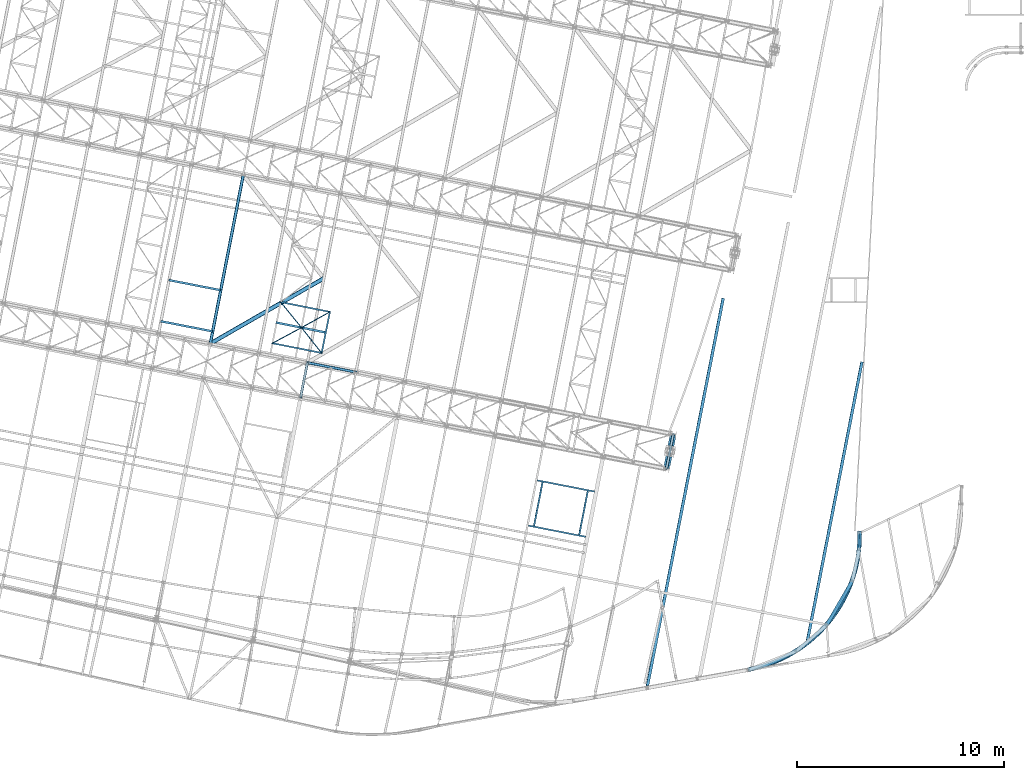
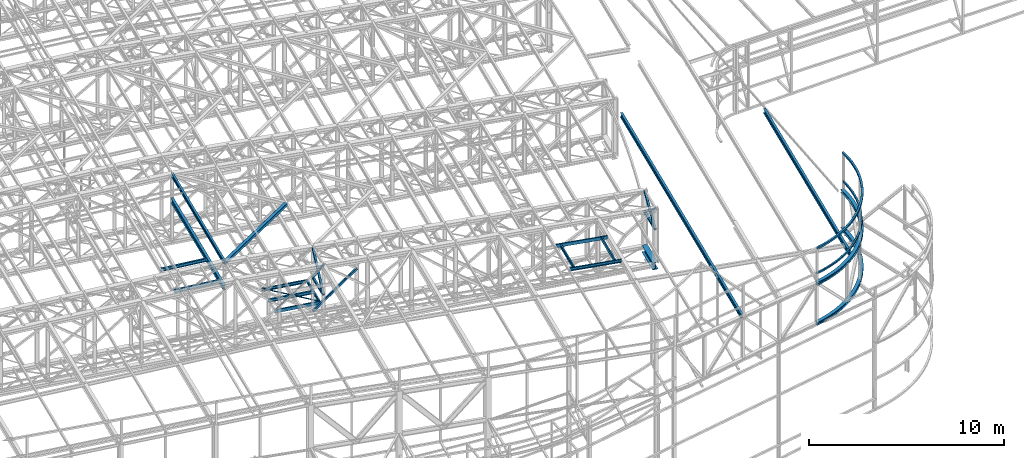
# One storey, part 59 of 215: 26 beams, 6 members, 32 elements without a shape of their own.
"""IFC2X3 building model written with IfcOpenShell, lengths in millimetres."""

from ifc_helpers import new_model, entity, si_unit, frame, origin_with_axes, origin_2d_with_axis, place, context, subcontext, project, spatial, hollow_rectangle, i_section, u_section, extrude, clip, halfspace, material, type_object, element, aggregate, save


model = new_model("IFC2X3")

# Units and contexts
model_context = context("Model", 3, precision=1e-05, world=origin_with_axes())
body_context = subcontext(model_context, "Body", "Model", "MODEL_VIEW")
ifc_project = project(units=[si_unit("LENGTHUNIT", "METRE", prefix="MILLI"), si_unit("AREAUNIT", "SQUARE_METRE"), si_unit("VOLUMEUNIT", "CUBIC_METRE"), si_unit("MASSUNIT", "GRAM", prefix="KILO"), si_unit("TIMEUNIT", "SECOND"), si_unit("PLANEANGLEUNIT", "RADIAN"), si_unit("SOLIDANGLEUNIT", "STERADIAN"), si_unit("THERMODYNAMICTEMPERATUREUNIT", "DEGREE_CELSIUS"), si_unit("LUMINOUSINTENSITYUNIT", "LUMEN")], contexts=[model_context])

# Site, building, storey
site_placement = place(None, origin_with_axes())
site = spatial("IfcSite", under=ifc_project, at=site_placement, CompositionType="ELEMENT")
building_placement = place(site_placement, origin_with_axes())
building = spatial("IfcBuilding", under=site, at=building_placement, Name="Undefined", CompositionType="ELEMENT")
storey_placement = place(building_placement, origin_with_axes())
storey = spatial("IfcBuildingStorey", under=building, at=storey_placement, Name="Undefined", CompositionType="ELEMENT", Elevation=0.0)

# Assembly, beam
assembly_1_placement = place(storey_placement, origin_with_axes())
assembly_1 = element("IfcElementAssembly", 1, at=assembly_1_placement, inside=storey, Name="Steel Assembly", AssemblyPlace="NOTDEFINED", PredefinedType="RIGID_FRAME")
ifc_material_1 = material(Name="STEEL/S275JR")
beam_type_1 = type_object("IfcBeamType", PredefinedType="NOTDEFINED")
beam_1_placement = place(assembly_1_placement, frame((98906.6966895589, 9997.56402703412, 12402.9925032266), z_axis=(0.0281714399984521, 0.00473133599973984, 0.999591908944881), x_axis=(-0.630520880023698, -0.775876050029161, 0.0214423610008059)))
beam_1 = element("IfcBeam", 2, at=beam_1_placement, type_object=beam_type_1, material=ifc_material_1, Name="LISSE", context=body_context, shape_type="SweptSolid", body=[
    entity("IfcRevolvedAreaSolid", entity("IfcRectangleHollowProfileDef", "AREA", None, entity("IfcAxis2Placement2D", entity("IfcCartesianPoint", [0.0, 0.0]), entity("IfcDirection", [1.0, 0.0])), 100.0, 100.0, 4.0, 4.0, 8.0), entity("IfcAxis2Placement3D", entity("IfcCartesianPoint", [8580.86874951581, -2.91266237782568e-11, 1.78921853461773e-12]), entity("IfcDirection", [-0.77200215890436, 0.635619907371541, 4.88367008734358e-18]), entity("IfcDirection", [-0.635619907371541, -0.77200215890436, -4.7317098688111e-19])), entity("IfcAxis1Placement", entity("IfcCartesianPoint", [6750.0, 0.0, 0.0]), entity("IfcDirection", [0.0, 1.0, 0.0])), 1.37762248286978),
])
aggregate(assembly_1, [beam_1])

assembly_2_placement = place(storey_placement, origin_with_axes())
assembly_2 = element("IfcElementAssembly", 3, at=assembly_2_placement, inside=storey, Name="Steel Assembly", AssemblyPlace="NOTDEFINED", PredefinedType="RIGID_FRAME")
beam_type_2 = type_object("IfcBeamType", Name="IPE240", PredefinedType="NOTDEFINED")
beam_2_placement = place(assembly_2_placement, frame((67523.0263426016, 19103.76567383, 12797.7153095357), z_axis=(0.0, 0.0, 1.0), x_axis=(0.191859470081235, 0.981422408415534, 0.0)))
beam_2 = element("IfcBeam", 4, at=beam_2_placement, type_object=beam_type_2, material=ifc_material_1, ObjectType="IPE240", context=body_context, shape_type="SweptSolid", body=[
    extrude(i_section(OverallWidth=120.0, OverallDepth=240.0, WebThickness=6.199999809, FlangeThickness=9.800000191, FilletRadius=15.0, at=origin_2d_with_axis()), frame((8299.99526300685, 1.47838788079098e-11, -1.71639879146031e-21), z_axis=(-1.0, 0.0, 0.0), x_axis=(-6.93889390390723e-18, -1.0, -3.46944695195361e-18)), (0.0, 0.0, 1.0), 8300.0),
])
aggregate(assembly_2, [beam_2])

assembly_3_placement = place(storey_placement, origin_with_axes())
assembly_3 = element("IfcElementAssembly", 5, at=assembly_3_placement, inside=storey, Name="Steel Assembly", AssemblyPlace="NOTDEFINED", PredefinedType="RIGID_FRAME")
beam_type_3 = type_object("IfcBeamType", Name="IPE270", PredefinedType="NOTDEFINED")
beam_3_placement = place(assembly_3_placement, frame((96342.8816697116, 4697.38975227182, 11822.2868772041), z_axis=(0.0304080349965938, -0.00594450399933318, 0.999519891888024), x_axis=(0.191859470081235, 0.981422408415534, 0.0)))
beam_3 = element("IfcBeam", 6, at=beam_3_placement, type_object=beam_type_3, material=ifc_material_1, ObjectType="IPE270", context=body_context, shape_type="SweptSolid", body=[
    extrude(i_section(OverallWidth=135.0, OverallDepth=270.0, WebThickness=6.599999905, FlangeThickness=10.19999981, FilletRadius=15.0, at=origin_2d_with_axis()), frame((13786.1928349318, 0.0, 1.81898940354586e-12), z_axis=(-1.0, 0.0, 0.0), x_axis=(-6.93889390390723e-18, -1.0, -3.46944695195361e-18)), (0.0, 0.0, 1.0), 13786.2),
])
aggregate(assembly_3, [beam_3])

assembly_4_placement = place(storey_placement, origin_with_axes())
assembly_4 = element("IfcElementAssembly", 7, at=assembly_4_placement, inside=storey, Name="Steel Assembly", AssemblyPlace="NOTDEFINED", PredefinedType="RIGID_FRAME")
beam_4_placement = place(assembly_4_placement, frame((88675.9862604393, 2825.15409559014, 12044.3992258659), z_axis=(0.0304080349965938, -0.00594450399933318, 0.999519891888024), x_axis=(0.191859470081235, 0.981422408415534, 0.0)))
beam_4 = element("IfcBeam", 8, at=beam_4_placement, type_object=beam_type_3, material=ifc_material_1, ObjectType="IPE270", context=body_context, shape_type="Clipping", body=[
    clip(extrude(i_section(OverallWidth=135.0, OverallDepth=270.0, WebThickness=6.599999905, FlangeThickness=10.19999981, FilletRadius=15.0, at=origin_2d_with_axis()), frame((18826.2441793608, 5.22533243878542e-13, -1.83531856741706e-12), z_axis=(-1.0, 0.0, 0.0), x_axis=(-6.93889390390723e-18, -1.0, -3.46944695195361e-18)), (0.0, 0.0, 1.0), 19120.8), halfspace(frame((-140.77964421397, -247.452609499334, 193.325370493829), z_axis=(0.932135442503494, 0.361935961367028, -0.0112194785146274), x_axis=(-1.11477173049934e-07, 0.0309836363285431, 0.999519891888024)), True)),
])
aggregate(assembly_4, [beam_4])

assembly_5_placement = place(storey_placement, origin_with_axes())
assembly_5 = element("IfcElementAssembly", 9, at=assembly_5_placement, inside=storey, Name="Steel Assembly", AssemblyPlace="NOTDEFINED", PredefinedType="RIGID_FRAME")
beam_type_4 = type_object("IfcBeamType", PredefinedType="NOTDEFINED")
beam_5_placement = place(assembly_5_placement, frame((98914.0804124177, 10055.2776774889, 14159.9992949207), z_axis=(0.0, 0.0, 1.0), x_axis=(-0.627240919701762, -0.778825287629687, -4.71999999842984e-07)))
beam_5 = element("IfcBeam", 10, at=beam_5_placement, type_object=beam_type_4, material=ifc_material_1, Name="LISSE", context=body_context, shape_type="SweptSolid", body=[
    entity("IfcRevolvedAreaSolid", entity("IfcRectangleHollowProfileDef", "AREA", None, entity("IfcAxis2Placement2D", entity("IfcCartesianPoint", [0.0, 0.0]), entity("IfcDirection", [1.0, 0.0])), 120.0, 120.0, 4.0, 4.0, 8.0), entity("IfcAxis2Placement3D", entity("IfcCartesianPoint", [8649.27113164034, 7.33174074846522e-14, 0.0]), entity("IfcDirection", [-0.75881988012704, 0.651300537021109, 4.46820122564736e-23]), entity("IfcDirection", [-0.651300537021109, -0.75881988012704, -5.20583006723259e-23])), entity("IfcAxis1Placement", entity("IfcCartesianPoint", [6640.0, 0.0, 0.0]), entity("IfcDirection", [0.0, 1.0, 0.0])), 1.4185941460835),
])
aggregate(assembly_5, [beam_5])

assembly_6_placement = place(storey_placement, origin_with_axes())
assembly_6 = element("IfcElementAssembly", 11, at=assembly_6_placement, inside=storey, Name="Steel Assembly", AssemblyPlace="NOTDEFINED", PredefinedType="RIGID_FRAME")
beam_type_5 = type_object("IfcBeamType", PredefinedType="NOTDEFINED")
beam_6_placement = place(assembly_6_placement, frame((89549.9522218589, 13065.5149440657, 10795.9999790824), z_axis=(0.981422364268518, -0.191859461052493, -0.000300197000082615), x_axis=(0.191859470081235, 0.981422408415534, 0.0)))
beam_6 = element("IfcBeam", 12, at=beam_6_placement, type_object=beam_type_5, material=ifc_material_1, context=body_context, shape_type="SweptSolid", body=[
    extrude(hollow_rectangle(XDim=120.0, YDim=120.0, WallThickness=5.0, InnerFilletRadius=5.0, OuterFilletRadius=10.0, at=origin_2d_with_axis()), frame((1699.99999941724, 1.81898940354586e-12, 0.0), z_axis=(-1.0, 0.0, 0.0), x_axis=(-6.93889390390723e-18, -1.0, -3.46944695195361e-18)), (0.0, 0.0, 1.0), 1700.0),
])
aggregate(assembly_6, [beam_6])

assembly_7_placement = place(storey_placement, origin_with_axes())
assembly_7 = element("IfcElementAssembly", 13, at=assembly_7_placement, inside=storey, Name="Steel Assembly", AssemblyPlace="NOTDEFINED", PredefinedType="RIGID_FRAME")
beam_7_placement = place(assembly_7_placement, frame((71884.9577831845, 16518.8662924301, 10796.0000008389), z_axis=(0.981422364268518, -0.191859461052493, -0.000300197000082615), x_axis=(0.191859470081235, 0.981422408415534, 0.0)))
beam_7 = element("IfcBeam", 14, at=beam_7_placement, type_object=beam_type_5, material=ifc_material_1, context=body_context, shape_type="SweptSolid", body=[
    extrude(hollow_rectangle(XDim=120.0, YDim=120.0, WallThickness=5.0, InnerFilletRadius=5.0, OuterFilletRadius=10.0, at=origin_2d_with_axis()), frame((1699.99999941724, 1.81898940354586e-12, 0.0), z_axis=(-1.0, 0.0, 0.0), x_axis=(-6.93889390390723e-18, -1.0, -3.46944695195361e-18)), (0.0, 0.0, 1.0), 1700.0),
])
aggregate(assembly_7, [beam_7])

assembly_8_placement = place(storey_placement, origin_with_axes())
assembly_8 = element("IfcElementAssembly", 15, at=assembly_8_placement, inside=storey, Name="Steel Assembly", AssemblyPlace="NOTDEFINED", PredefinedType="RIGID_FRAME")
beam_type_6 = type_object("IfcBeamType", PredefinedType="NOTDEFINED")
beam_8_placement = place(assembly_8_placement, frame((73298.5172590752, 20638.5699481705, 8745.0), z_axis=(0.0, 0.0, -1.0), x_axis=(-0.874701673841488, -0.484661718912169, 0.0)))
beam_8 = element("IfcBeam", 16, at=beam_8_placement, type_object=beam_type_6, material=ifc_material_1, context=body_context, shape_type="SweptSolid", body=[
    extrude(hollow_rectangle(XDim=50.0, YDim=50.0, WallThickness=3.0, InnerFilletRadius=3.0, OuterFilletRadius=6.0, at=origin_2d_with_axis()), frame((1569.58413229395, 0.0, 0.0), z_axis=(-1.0, 0.0, 0.0), x_axis=(-6.93889390390723e-18, -1.0, -3.46944695195361e-18)), (0.0, 0.0, 1.0), 1569.6),
])
aggregate(assembly_8, [beam_8])

assembly_9_placement = place(storey_placement, origin_with_axes())
assembly_9 = element("IfcElementAssembly", 17, at=assembly_9_placement, inside=storey, Name="Steel Assembly", AssemblyPlace="NOTDEFINED", PredefinedType="RIGID_FRAME")
beam_9_placement = place(assembly_9_placement, frame((71925.5993907337, 19877.8526054458, 8745.0), z_axis=(0.0, 0.0, -1.0), x_axis=(0.62171930275205, -0.783240134687635, 0.0)))
beam_9 = element("IfcBeam", 18, at=beam_9_placement, type_object=beam_type_6, material=ifc_material_1, context=body_context, shape_type="SweptSolid", body=[
    extrude(hollow_rectangle(XDim=50.0, YDim=50.0, WallThickness=3.0, InnerFilletRadius=3.0, OuterFilletRadius=6.0, at=origin_2d_with_axis()), frame((1562.91685494035, 8.67593138964756e-14, 0.0), z_axis=(-1.0, 0.0, 0.0), x_axis=(-6.93889390390723e-18, -1.0, -3.46944695195361e-18)), (0.0, 0.0, 1.0), 1562.9),
])
aggregate(assembly_9, [beam_9])

assembly_10_placement = place(storey_placement, origin_with_axes())
assembly_10 = element("IfcElementAssembly", 19, at=assembly_10_placement, inside=storey, Name="Steel Assembly", AssemblyPlace="NOTDEFINED", PredefinedType="RIGID_FRAME")
beam_10_placement = place(assembly_10_placement, frame((71925.5993907337, 19877.8526054458, 8745.0), z_axis=(0.0, 0.0, -1.0), x_axis=(-0.88073588077161, -0.473607757877186, 0.0)))
beam_10 = element("IfcBeam", 20, at=beam_10_placement, type_object=beam_type_6, material=ifc_material_1, context=body_context, shape_type="SweptSolid", body=[
    extrude(hollow_rectangle(XDim=50.0, YDim=50.0, WallThickness=3.0, InnerFilletRadius=3.0, OuterFilletRadius=6.0, at=origin_2d_with_axis()), frame((1588.19273663173, 0.0, 0.0), z_axis=(-1.0, 0.0, 0.0), x_axis=(-6.93889390390723e-18, -1.0, -3.46944695195361e-18)), (0.0, 0.0, 1.0), 1588.2),
])
aggregate(assembly_10, [beam_10])

assembly_11_placement = place(storey_placement, origin_with_axes())
assembly_11 = element("IfcElementAssembly", 21, at=assembly_11_placement, inside=storey, Name="Steel Assembly", AssemblyPlace="NOTDEFINED", PredefinedType="RIGID_FRAME")
beam_11_placement = place(assembly_11_placement, frame((70922.2766673202, 21111.7996845445, 8745.0), z_axis=(0.0, 0.0, -1.0), x_axis=(0.630873132037037, -0.775886004045555, 0.0)))
beam_11 = element("IfcBeam", 22, at=beam_11_placement, type_object=beam_type_6, material=ifc_material_1, context=body_context, shape_type="SweptSolid", body=[
    extrude(hollow_rectangle(XDim=50.0, YDim=50.0, WallThickness=3.0, InnerFilletRadius=3.0, OuterFilletRadius=6.0, at=origin_2d_with_axis()), frame((1590.37161734532, 0.0, 0.0), z_axis=(-1.0, 0.0, 0.0), x_axis=(-6.93889390390723e-18, -1.0, -3.46944695195361e-18)), (0.0, 0.0, 1.0), 1590.4),
])
aggregate(assembly_11, [beam_11])

assembly_12_placement = place(storey_placement, origin_with_axes())
assembly_12 = element("IfcElementAssembly", 23, at=assembly_12_placement, inside=storey, Name="Steel Assembly", AssemblyPlace="NOTDEFINED", PredefinedType="RIGID_FRAME")
beam_type_7 = type_object("IfcBeamType", Name="HEA200", PredefinedType="NOTDEFINED")
beam_12_placement = place(assembly_12_placement, frame((93479.7328649476, 3368.83150190775, 9437.01352754076), z_axis=(0.000129332000061068, -0.000119496000059185, 0.99999998449697), x_axis=(0.627699932922019, 0.77845538990329, 1.1840999998577e-05)))
beam_12 = element("IfcBeam", 24, at=beam_12_placement, type_object=beam_type_7, material=ifc_material_1, Name="LISSE", ObjectType="HEA200", context=body_context, shape_type="SweptSolid", body=[
    entity("IfcRevolvedAreaSolid", entity("IfcIShapeProfileDef", "AREA", None, entity("IfcAxis2Placement2D", entity("IfcCartesianPoint", [0.0, 0.0]), entity("IfcDirection", [1.0, 0.0])), 200.0, 190.0, 6.5, 10.0, 18.0), entity("IfcAxis2Placement3D", entity("IfcCartesianPoint", [8594.30580938109, -1.47584509531207e-11, -1.81907675946801e-12]), entity("IfcDirection", [-0.759005876107548, -0.651083773437961, -2.75804862709024e-20]), entity("IfcDirection", [0.651083773437961, -0.759005876107548, -4.77636638805486e-20])), entity("IfcAxis1Placement", entity("IfcCartesianPoint", [-6600.0, 0.0, 0.0]), entity("IfcDirection", [-6.93889390390723e-18, -1.0, -3.46944695195361e-18])), 1.41802289847939),
])
aggregate(assembly_12, [beam_12])

assembly_13_placement = place(storey_placement, origin_with_axes())
assembly_13 = element("IfcElementAssembly", 25, at=assembly_13_placement, inside=storey, Name="Steel Assembly", AssemblyPlace="NOTDEFINED", PredefinedType="RIGID_FRAME")
beam_13_placement = place(assembly_13_placement, frame((93478.9723857367, 3367.80327592385, 11936.9299541571), z_axis=(0.00893090200412387, 0.0117881340054526, 0.999890633462511), x_axis=(0.627630384967869, 0.778371105960153, -0.0147824649992432)))
beam_13 = element("IfcBeam", 26, at=beam_13_placement, type_object=beam_type_7, material=ifc_material_1, Name="LISSE", ObjectType="HEA200", context=body_context, shape_type="SweptSolid", body=[
    entity("IfcRevolvedAreaSolid", entity("IfcIShapeProfileDef", "AREA", None, entity("IfcAxis2Placement2D", entity("IfcCartesianPoint", [0.0, 0.0]), entity("IfcDirection", [1.0, 0.0])), 200.0, 190.0, 6.5, 10.0, 18.0), entity("IfcAxis2Placement3D", entity("IfcCartesianPoint", [8595.11902876957, -1.37509093900164e-11, 0.0]), entity("IfcDirection", [-0.75895302413577, -0.651145380967391, 1.94142640078405e-18]), entity("IfcDirection", [0.651145380967392, -0.75895302413577, 2.26286092335173e-18])), entity("IfcAxis1Placement", entity("IfcCartesianPoint", [-6600.0, 0.0, 0.0]), entity("IfcDirection", [-6.93889390390723e-18, -1.0, -3.46944695195361e-18])), 1.41818524155571),
])
aggregate(assembly_13, [beam_13])

assembly_14_placement = place(storey_placement, origin_with_axes())
assembly_14 = element("IfcElementAssembly", 27, at=assembly_14_placement, inside=storey, Name="Steel Assembly", AssemblyPlace="NOTDEFINED", PredefinedType="RIGID_FRAME")
ifc_material_2 = material(Name="STEEL/S235JR")
beam_type_8 = type_object("IfcBeamType", Name="UPN200", PredefinedType="NOTDEFINED")
beam_14_placement = place(assembly_14_placement, frame((85748.4116463726, 11988.0081850179, 12222.9605386373), z_axis=(-0.0304080339975108, 0.00594450399951394, -0.999519891918418), x_axis=(-0.19187685493533, -0.98141900966922, -1.21999999765762e-07)))
beam_14 = element("IfcBeam", 28, at=beam_14_placement, type_object=beam_type_8, material=ifc_material_2, ObjectType="UPN200", context=body_context, shape_type="SweptSolid", body=[
    extrude(u_section(Depth=200.0, FlangeWidth=75.0, WebThickness=8.5, FlangeThickness=11.5, FilletRadius=11.5, EdgeRadius=6.0, FlangeSlope=0.0798299857122373, at=origin_2d_with_axis()), frame((2150.01524213469, 1.45109582611845e-11, -1.81736478151208e-12), z_axis=(-1.0, 0.0, 0.0), x_axis=(-6.93889390390723e-18, -1.0, -3.46944695195361e-18)), (0.0, 0.0, 1.0), 2150.0),
])
aggregate(assembly_14, [beam_14])

assembly_15_placement = place(storey_placement, origin_with_axes())
assembly_15 = element("IfcElementAssembly", 29, at=assembly_15_placement, inside=storey, Name="Steel Assembly", AssemblyPlace="NOTDEFINED", PredefinedType="RIGID_FRAME")
beam_15_placement = place(assembly_15_placement, frame((83565.8100950878, 12414.7364980797, 12291.8989616812), z_axis=(0.0304080349965938, -0.00594450399933318, 0.999519891888024), x_axis=(-0.19187685493533, -0.98141900966922, -1.21999999765762e-07)))
beam_15 = element("IfcBeam", 30, at=beam_15_placement, type_object=beam_type_8, material=ifc_material_2, ObjectType="UPN200", context=body_context, shape_type="SweptSolid", body=[
    extrude(u_section(Depth=200.0, FlangeWidth=75.0, WebThickness=8.5, FlangeThickness=11.5, FilletRadius=11.5, EdgeRadius=6.0, FlangeSlope=0.0798299857122373, at=origin_2d_with_axis()), frame((2150.01524213469, 1.45109582611845e-11, -1.81736478151208e-12), z_axis=(-1.0, 0.0, 0.0), x_axis=(-6.93889390390723e-18, -1.0, -3.46944695195361e-18)), (0.0, 0.0, 1.0), 2150.0),
])
aggregate(assembly_15, [beam_15])

assembly_16_placement = place(storey_placement, origin_with_axes())
assembly_16 = element("IfcElementAssembly", 31, at=assembly_16_placement, inside=storey, Name="Steel Assembly", AssemblyPlace="NOTDEFINED", PredefinedType="RIGID_FRAME")
beam_16_placement = place(assembly_16_placement, frame((86070.9553474713, 11963.1688302822, 12213.0001961296), z_axis=(0.0304080349965938, -0.00594450399933318, 0.999519891888024), x_axis=(-0.980948088205167, 0.191783373040111, 0.03098364200648)))
beam_16 = element("IfcBeam", 32, at=beam_16_placement, type_object=beam_type_8, material=ifc_material_2, ObjectType="UPN200", context=body_context, shape_type="SweptSolid", body=[
    extrude(u_section(Depth=200.0, FlangeWidth=75.0, WebThickness=8.5, FlangeThickness=11.5, FilletRadius=11.5, EdgeRadius=6.0, FlangeSlope=0.0798299857122373, at=origin_2d_with_axis()), frame((2813.33885247078, 3.65331263007744e-12, 0.0), z_axis=(-1.0, 0.0, 0.0), x_axis=(-6.93889390390723e-18, -1.0, -3.46944695195361e-18)), (0.0, 0.0, 1.0), 2813.3),
])
aggregate(assembly_16, [beam_16])

assembly_17_placement = place(storey_placement, origin_with_axes())
assembly_17 = element("IfcElementAssembly", 33, at=assembly_17_placement, inside=storey, Name="Steel Assembly", AssemblyPlace="NOTDEFINED", PredefinedType="RIGID_FRAME")
beam_17_placement = place(assembly_17_placement, frame((82884.2783117451, 10319.0498982606, 12300.1676955322), z_axis=(0.0304080349965938, -0.00594450399933318, 0.999519891888024), x_axis=(0.980948088205167, -0.191783373040112, -0.0309836420064805)))
beam_17 = element("IfcBeam", 34, at=beam_17_placement, type_object=beam_type_8, material=ifc_material_2, ObjectType="UPN200", context=body_context, shape_type="SweptSolid", body=[
    extrude(u_section(Depth=200.0, FlangeWidth=75.0, WebThickness=8.5, FlangeThickness=11.5, FilletRadius=11.5, EdgeRadius=6.0, FlangeSlope=0.0798299857122373, at=origin_2d_with_axis()), frame((2813.33885247078, 3.65331263007744e-12, 0.0), z_axis=(-1.0, 0.0, 0.0), x_axis=(-6.93889390390723e-18, -1.0, -3.46944695195361e-18)), (0.0, 0.0, 1.0), 2813.3),
])
aggregate(assembly_17, [beam_17])

assembly_18_placement = place(storey_placement, origin_with_axes())
assembly_18 = element("IfcElementAssembly", 35, at=assembly_18_placement, inside=storey, Name="Steel Assembly", AssemblyPlace="NOTDEFINED", PredefinedType="RIGID_FRAME")
beam_18_placement = place(assembly_18_placement, frame((73335.3991556828, 20631.2233576119, 8670.00000003361), z_axis=(0.0, 0.0, -1.0), x_axis=(-0.98073271027445, 0.195354424054668, 0.0)))
beam_18 = element("IfcBeam", 36, at=beam_18_placement, type_object=beam_type_8, material=ifc_material_1, ObjectType="UPN200", context=body_context, shape_type="SweptSolid", body=[
    extrude(u_section(Depth=200.0, FlangeWidth=75.0, WebThickness=8.5, FlangeThickness=11.5, FilletRadius=11.5, EdgeRadius=6.0, FlangeSlope=0.0798299857122373, at=origin_2d_with_axis()), frame((2498.0138875703, 0.0, 0.0), z_axis=(-1.0, 0.0, 0.0), x_axis=(-6.93889390390723e-18, -1.0, -3.46944695195361e-18)), (0.0, 0.0, 1.0), 2498.0),
])
aggregate(assembly_18, [beam_18])

assembly_19_placement = place(storey_placement, origin_with_axes())
assembly_19 = element("IfcElementAssembly", 37, at=assembly_19_placement, inside=storey, Name="Steel Assembly", AssemblyPlace="NOTDEFINED", PredefinedType="RIGID_FRAME")
beam_19_placement = place(assembly_19_placement, frame((70490.0422722032, 19132.9945603605, 8670.00000000005), z_axis=(0.0, 0.0, -1.0), x_axis=(0.980751595312344, -0.195259592062186, 0.0)))
beam_19 = element("IfcBeam", 38, at=beam_19_placement, type_object=beam_type_8, material=ifc_material_1, ObjectType="UPN200", context=body_context, shape_type="SweptSolid", body=[
    extrude(u_section(Depth=200.0, FlangeWidth=75.0, WebThickness=8.5, FlangeThickness=11.5, FilletRadius=11.5, EdgeRadius=6.0, FlangeSlope=0.0798299857122373, at=origin_2d_with_axis()), frame((2484.56851766432, 0.0, 0.0), z_axis=(-1.0, 0.0, 0.0), x_axis=(-6.93889390390723e-18, -1.0, -3.46944695195361e-18)), (0.0, 0.0, 1.0), 2484.6),
])
aggregate(assembly_19, [beam_19])

assembly_20_placement = place(storey_placement, origin_with_axes())
assembly_20 = element("IfcElementAssembly", 39, at=assembly_20_placement, inside=storey, Name="Steel Assembly", AssemblyPlace="NOTDEFINED", PredefinedType="RIGID_FRAME")
beam_20_placement = place(assembly_20_placement, frame((72889.8834002692, 18617.0481906557, 8670.00000003361), z_axis=(0.0, 0.0, -1.0), x_axis=(0.198134226938794, 0.9801748966972, 0.0)))
beam_20 = element("IfcBeam", 40, at=beam_20_placement, type_object=beam_type_8, material=ifc_material_1, ObjectType="UPN200", context=body_context, shape_type="SweptSolid", body=[
    extrude(u_section(Depth=200.0, FlangeWidth=75.0, WebThickness=8.5, FlangeThickness=11.5, FilletRadius=11.5, EdgeRadius=6.0, FlangeSlope=0.0798299857122373, at=origin_2d_with_axis()), frame((2100.01570650496, 0.0, 1.81898940354586e-12), z_axis=(-1.0, 0.0, 0.0), x_axis=(-6.93889390390723e-18, -1.0, -3.46944695195361e-18)), (0.0, 0.0, 1.0), 2100.0),
])
aggregate(assembly_20, [beam_20])

# Assembly, member
assembly_21_placement = place(storey_placement, origin_with_axes())
assembly_21 = element("IfcElementAssembly", 41, at=assembly_21_placement, inside=storey, Name="Steel Assembly", AssemblyPlace="NOTDEFINED", PredefinedType="RIGID_FRAME")
member_type_1 = type_object("IfcMemberType", PredefinedType="NOTDEFINED")
member_1_placement = place(assembly_21_placement, frame((89876.1133195395, 14733.9330380509, 10795.9999795361), z_axis=(0.981457773618154, -0.191678330925429, 0.000236765999907874), x_axis=(-0.151087994965764, -0.772863306824858, 0.616323556860332)))
member_1 = element("IfcMember", 42, at=member_1_placement, type_object=member_type_1, material=ifc_material_1, context=body_context, shape_type="SweptSolid", body=[
    extrude(hollow_rectangle(XDim=120.0, YDim=120.0, WallThickness=5.0, InnerFilletRadius=5.0, OuterFilletRadius=10.0, at=origin_2d_with_axis()), frame((2158.74925246308, 7.39579227040727e-12, 1.19366552097968e-14), z_axis=(-1.0, 0.0, 0.0), x_axis=(-6.93889390390723e-18, -1.0, -3.46944695195361e-18)), (0.0, 0.0, 1.0), 2158.7),
])
aggregate(assembly_21, [member_1])

assembly_22_placement = place(storey_placement, origin_with_axes())
assembly_22 = element("IfcElementAssembly", 43, at=assembly_22_placement, inside=storey, Name="Steel Assembly", AssemblyPlace="NOTDEFINED", PredefinedType="RIGID_FRAME")
member_2_placement = place(assembly_22_placement, frame((89549.9522218589, 13065.5149440657, 10795.9999790824), z_axis=(0.981457773617921, -0.191678330925384, -0.000236766999908156), x_axis=(0.151087995965099, 0.77286330982147, 0.61632355285763)))
member_2 = element("IfcMember", 44, at=member_2_placement, type_object=member_type_1, material=ifc_material_1, context=body_context, shape_type="SweptSolid", body=[
    extrude(hollow_rectangle(XDim=120.0, YDim=120.0, WallThickness=5.0, InnerFilletRadius=5.0, OuterFilletRadius=10.0, at=origin_2d_with_axis()), frame((2158.74925246308, 7.39579227040727e-12, 1.19366552097968e-14), z_axis=(-1.0, 0.0, 0.0), x_axis=(-6.93889390390723e-18, -1.0, -3.46944695195361e-18)), (0.0, 0.0, 1.0), 2158.7),
])
aggregate(assembly_22, [member_2])

assembly_23_placement = place(storey_placement, origin_with_axes())
assembly_23 = element("IfcElementAssembly", 45, at=assembly_23_placement, inside=storey, Name="Steel Assembly", AssemblyPlace="NOTDEFINED", PredefinedType="RIGID_FRAME")
member_3_placement = place(assembly_23_placement, frame((72211.1188818404, 18187.2843862393, 10796.0000008371), z_axis=(0.981465144014204, -0.191640629002775, 0.000200999000003501), x_axis=(-0.128461058963395, -0.657119307812757, 0.742759699788354)))
member_3 = element("IfcMember", 46, at=member_3_placement, type_object=member_type_1, material=ifc_material_1, context=body_context, shape_type="SweptSolid", body=[
    extrude(hollow_rectangle(XDim=120.0, YDim=120.0, WallThickness=5.0, InnerFilletRadius=5.0, OuterFilletRadius=10.0, at=origin_2d_with_axis()), frame((2538.98807297308, -7.4168997650766e-12, -1.4616192556948e-11), z_axis=(-1.0, 0.0, 0.0), x_axis=(-6.93889390390723e-18, -1.0, -3.46944695195361e-18)), (0.0, 0.0, 1.0), 2539.0),
])
aggregate(assembly_23, [member_3])

assembly_24_placement = place(storey_placement, origin_with_axes())
assembly_24 = element("IfcElementAssembly", 47, at=assembly_24_placement, inside=storey, Name="Steel Assembly", AssemblyPlace="NOTDEFINED", PredefinedType="RIGID_FRAME")
member_4_placement = place(assembly_24_placement, frame((71884.9577831845, 16518.8662924301, 10796.0000008389), z_axis=(0.981465144014204, -0.191640629002775, -0.000200999000003501), x_axis=(0.128461059990898, 0.657119311953447, 0.742759695947379)))
member_4 = element("IfcMember", 48, at=member_4_placement, type_object=member_type_1, material=ifc_material_1, context=body_context, shape_type="SweptSolid", body=[
    extrude(hollow_rectangle(XDim=120.0, YDim=120.0, WallThickness=5.0, InnerFilletRadius=5.0, OuterFilletRadius=10.0, at=origin_2d_with_axis()), frame((2538.98807297308, -7.4168997650766e-12, -1.4616192556948e-11), z_axis=(-1.0, 0.0, 0.0), x_axis=(-6.93889390390723e-18, -1.0, -3.46944695195361e-18)), (0.0, 0.0, 1.0), 2539.0),
])
aggregate(assembly_24, [member_4])

assembly_25_placement = place(storey_placement, origin_with_axes())
assembly_25 = element("IfcElementAssembly", 49, at=assembly_25_placement, inside=storey, Name="Steel Assembly", AssemblyPlace="NOTDEFINED", PredefinedType="RIGID_FRAME")
member_5_placement = place(assembly_25_placement, frame((72215.8321185252, 18186.3629805541, 8654.99756498387), z_axis=(0.655817009937109, -0.128206468987706, -0.743953728928658), x_axis=(0.730132860802437, -0.142734564961378, 0.668231134819185)))
member_5 = element("IfcMember", 50, at=member_5_placement, type_object=member_type_1, material=ifc_material_1, context=body_context, shape_type="SweptSolid", body=[
    extrude(hollow_rectangle(XDim=120.0, YDim=120.0, WallThickness=5.0, InnerFilletRadius=5.0, OuterFilletRadius=10.0, at=origin_2d_with_axis()), frame((3203.9848555289, -6.00376509824008e-14, -1.77856887857925e-13), z_axis=(-1.0, 0.0, 0.0), x_axis=(-6.93889390390723e-18, -1.0, -3.46944695195361e-18)), (0.0, 0.0, 1.0), 3204.0),
])
aggregate(assembly_25, [member_5])

# Assembly, beam
assembly_26_placement = place(storey_placement, origin_with_axes())
assembly_26 = element("IfcElementAssembly", 51, at=assembly_26_placement, inside=storey, Name="Steel Assembly", AssemblyPlace="NOTDEFINED", PredefinedType="RIGID_FRAME")
beam_type_9 = type_object("IfcBeamType", PredefinedType="NOTDEFINED")
beam_21_placement = place(assembly_26_placement, frame((73003.2302254503, 22260.9878472476, 12636.7977478893), z_axis=(0.0304080349965938, -0.00594450399933318, 0.999519891888024), x_axis=(-0.866468094253426, -0.498684012145856, 0.0233943940068423)))
beam_21 = element("IfcBeam", 52, at=beam_21_placement, type_object=beam_type_9, material=ifc_material_1, context=body_context, shape_type="SweptSolid", body=[
    extrude(hollow_rectangle(XDim=200.0, YDim=200.0, WallThickness=10.0, InnerFilletRadius=15.0, OuterFilletRadius=25.0, at=origin_2d_with_axis()), frame((6329.49911177436, 3.28490541050796e-12, -2.19598614007387e-14), z_axis=(-1.0, 0.0, 0.0), x_axis=(-6.93889390390723e-18, -1.0, -3.46944695195361e-18)), (0.0, 0.0, 1.0), 6329.5),
])
aggregate(assembly_26, [beam_21])

assembly_27_placement = place(storey_placement, origin_with_axes())
assembly_27 = element("IfcElementAssembly", 53, at=assembly_27_placement, inside=storey, Name="Steel Assembly", AssemblyPlace="NOTDEFINED", PredefinedType="RIGID_FRAME")
beam_type_10 = type_object("IfcBeamType", Name="IPE300", PredefinedType="NOTDEFINED")
beam_22_placement = place(assembly_27_placement, frame((67523.0275874459, 19103.7654335305, 11197.7200001516), z_axis=(0.0, 0.0, 1.0), x_axis=(0.191859470081235, 0.981422408415534, 0.0)))
beam_22 = element("IfcBeam", 54, at=beam_22_placement, type_object=beam_type_10, material=ifc_material_1, Name="SUPPORT", ObjectType="IPE300", context=body_context, shape_type="SweptSolid", body=[
    extrude(i_section(OverallWidth=150.0, OverallDepth=300.0, WebThickness=7.099999905, FlangeThickness=10.69999981, FilletRadius=15.0, at=origin_2d_with_axis()), frame((8299.99526300685, 1.47838788079098e-11, -1.71639879146031e-21), z_axis=(-1.0, 0.0, 0.0), x_axis=(-6.93889390390723e-18, -1.0, -3.46944695195361e-18)), (0.0, 0.0, 1.0), 8300.0),
])
aggregate(assembly_27, [beam_22])

assembly_28_placement = place(storey_placement, origin_with_axes())
assembly_28 = element("IfcElementAssembly", 55, at=assembly_28_placement, inside=storey, Name="Steel Assembly", AssemblyPlace="NOTDEFINED", PredefinedType="RIGID_FRAME")
beam_type_11 = type_object("IfcBeamType", Name="IPE200", PredefinedType="NOTDEFINED")
beam_23_placement = place(assembly_28_placement, frame((65523.5336508299, 22173.4478357523, 11169.0478650886), z_axis=(0.0303605499861654, -0.00593522099729565, -0.99952139054462), x_axis=(0.980952689077156, -0.191767651015084, 0.030935252002433)))
beam_23 = element("IfcBeam", 56, at=beam_23_placement, type_object=beam_type_11, material=ifc_material_1, ObjectType="IPE200", context=body_context, shape_type="SweptSolid", body=[
    extrude(i_section(OverallWidth=100.0, OverallDepth=200.0, WebThickness=5.599999905, FlangeThickness=8.5, FilletRadius=12.0, at=origin_2d_with_axis()), frame((2544.66727454958, 2.95700928513306e-14, 1.81016081542643e-12), z_axis=(-1.0, 0.0, 0.0), x_axis=(-6.93889390390723e-18, -1.0, -3.46944695195361e-18)), (0.0, 0.0, 1.0), 2544.7),
])
aggregate(assembly_28, [beam_23])

assembly_29_placement = place(storey_placement, origin_with_axes())
assembly_29 = element("IfcElementAssembly", 57, at=assembly_29_placement, inside=storey, Name="Steel Assembly", AssemblyPlace="NOTDEFINED", PredefinedType="RIGID_FRAME")
beam_24_placement = place(assembly_29_placement, frame((65134.4177042474, 20186.1615929721, 11169.0478650907), z_axis=(0.0303605499861654, -0.00593522099729565, -0.99952139054462), x_axis=(0.980952689077156, -0.191767651015084, 0.030935252002433)))
beam_24 = element("IfcBeam", 58, at=beam_24_placement, type_object=beam_type_11, material=ifc_material_1, ObjectType="IPE200", context=body_context, shape_type="SweptSolid", body=[
    extrude(i_section(OverallWidth=100.0, OverallDepth=200.0, WebThickness=5.599999905, FlangeThickness=8.5, FilletRadius=12.0, at=origin_2d_with_axis()), frame((2544.66727454958, 2.95700928513306e-14, 1.81016081542643e-12), z_axis=(-1.0, 0.0, 0.0), x_axis=(-6.93889390390723e-18, -1.0, -3.46944695195361e-18)), (0.0, 0.0, 1.0), 2544.7),
])
aggregate(assembly_29, [beam_24])

assembly_30_placement = place(storey_placement, origin_with_axes())
assembly_30 = element("IfcElementAssembly", 59, at=assembly_30_placement, inside=storey, Name="Steel Assembly", AssemblyPlace="NOTDEFINED", PredefinedType="RIGID_FRAME")
beam_25_placement = place(assembly_30_placement, frame((73125.6784362488, 19637.1666131742, 8670.00000000005), z_axis=(0.0, 0.0, -1.0), x_axis=(-0.980475237121594, 0.196642593024387, 0.0)))
beam_25 = element("IfcBeam", 60, at=beam_25_placement, type_object=beam_type_11, material=ifc_material_1, ObjectType="IPE200", context=body_context, shape_type="SweptSolid", body=[
    extrude(i_section(OverallWidth=100.0, OverallDepth=200.0, WebThickness=5.599999905, FlangeThickness=8.5, FilletRadius=12.0, at=origin_2d_with_axis()), frame((2486.4451615131, 0.0, 0.0), z_axis=(-1.0, 0.0, 0.0), x_axis=(-6.93889390390723e-18, -1.0, -3.46944695195361e-18)), (0.0, 0.0, 1.0), 2486.4),
])
aggregate(assembly_30, [beam_25])

# Assembly, member
assembly_31_placement = place(storey_placement, origin_with_axes())
assembly_31 = element("IfcElementAssembly", 61, at=assembly_31_placement, inside=storey, Name="Steel Assembly", AssemblyPlace="NOTDEFINED", PredefinedType="RIGID_FRAME")
member_type_2 = type_object("IfcMemberType", Name="HEA160", PredefinedType="NOTDEFINED")
member_6_placement = place(assembly_31_placement, frame((97291.9498765079, 5530.11328021747, 11899.6100006151), z_axis=(0.358267737049122, 0.616792503084565, 0.700864635096092), x_axis=(0.352024663175283, 0.606044448301767, -0.713294303355169)))
member_6 = element("IfcMember", 62, at=member_6_placement, type_object=member_type_2, material=ifc_material_1, Name="LISSE", ObjectType="HEA160", context=body_context, shape_type="SweptSolid", body=[
    extrude(i_section(OverallWidth=160.0, OverallDepth=152.0, WebThickness=6.0, FlangeThickness=9.0, FilletRadius=15.0, at=origin_2d_with_axis()), frame((3492.50820654345, 1.4382949161904e-11, -3.87746302459685e-13), z_axis=(-1.0, 0.0, 0.0), x_axis=(-6.93889390390723e-18, -1.0, -3.46944695195361e-18)), (0.0, 0.0, 1.0), 3492.5),
])
aggregate(assembly_31, [member_6])

# Assembly, beam
assembly_32_placement = place(storey_placement, origin_with_axes())
assembly_32 = element("IfcElementAssembly", 63, at=assembly_32_placement, inside=storey, Name="Steel Assembly", AssemblyPlace="NOTDEFINED", PredefinedType="RIGID_FRAME")
beam_type_12 = type_object("IfcBeamType", Name="HEA450", PredefinedType="NOTDEFINED")
beam_26_placement = place(assembly_32_placement, frame((89875.0090063711, 14734.0346600036, 8510.00000023335), z_axis=(0.0, 0.0, 1.0), x_axis=(-0.191222930987493, -0.98154663193582, 0.0)))
beam_26 = element("IfcBeam", 64, at=beam_26_placement, type_object=beam_type_12, material=ifc_material_1, ObjectType="HEA450", context=body_context, shape_type="SweptSolid", body=[
    extrude(i_section(OverallWidth=300.0, OverallDepth=440.0, WebThickness=11.5, FlangeThickness=21.0, FilletRadius=27.0, at=origin_2d_with_axis()), frame((1699.99999941724, 1.81898940354586e-12, 0.0), z_axis=(-1.0, 0.0, 0.0), x_axis=(-6.93889390390723e-18, -1.0, -3.46944695195361e-18)), (0.0, 0.0, 1.0), 1700.0),
])
aggregate(assembly_32, [beam_26])

save(model, "model.ifc")
